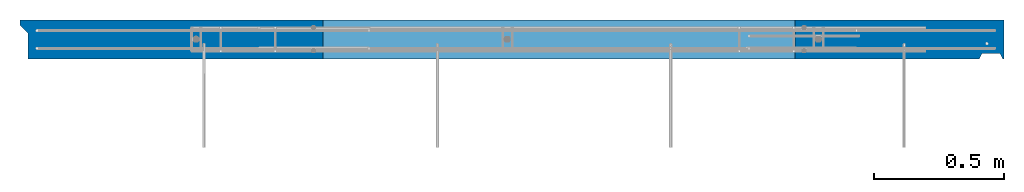
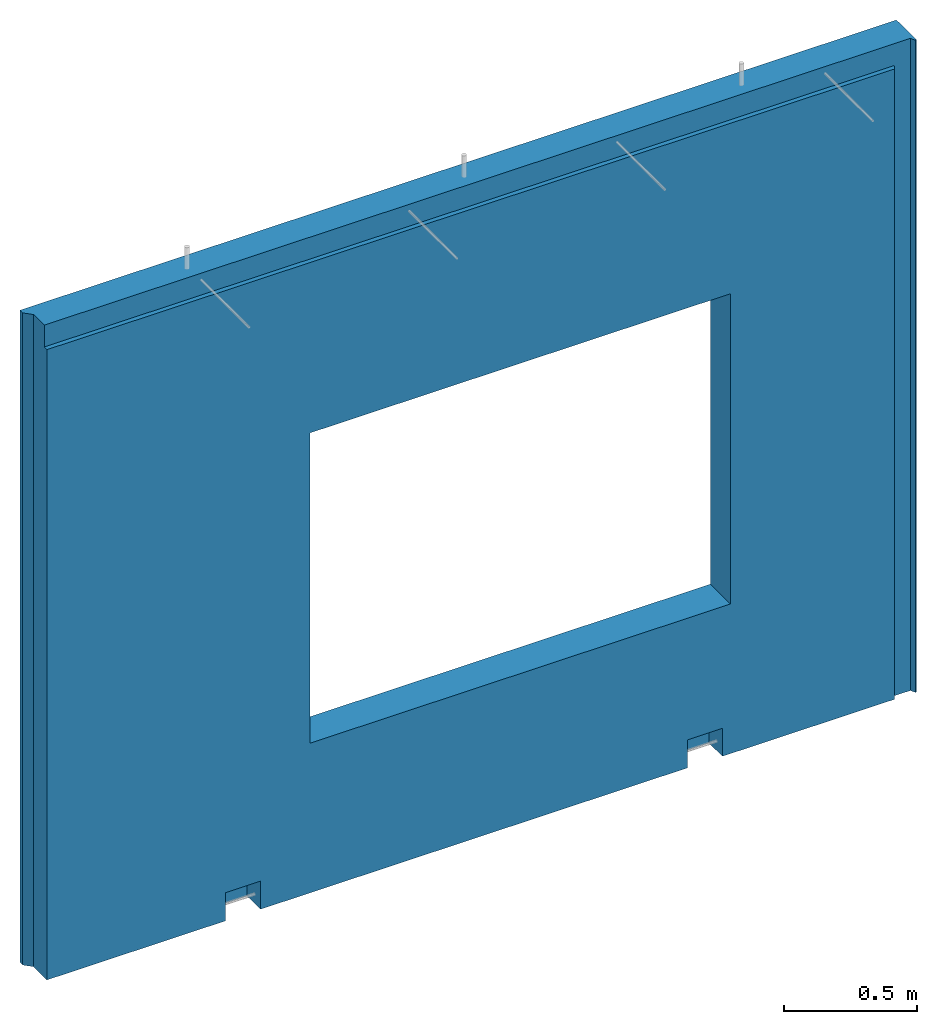
# One storey, part 3 of 3: 1 wall, 1 element without a shape of its own.
"""IFC2X3 building model written with IfcOpenShell, lengths in millimetres."""

import ifcopenshell
import ifcopenshell.guid

model = None  # the IFC model being written
_history = None  # IfcOwnerHistory: only IFC2X3 demands one
_inside = {}  # id of a spatial element -> (the spatial element, [elements in it])
_under = {}  # id of a project, library or spatial element -> (it, [spatial elements below it])
_declared = {}  # id of a project -> (the project, [libraries it declares])
_typed = {}  # id of a type object -> (the type object, [elements of that type])
_made_of = {}  # id of a material, layer set ... -> (it, [elements and type objects made of it])


def new_model(schema):
    """Start an empty IFC model of exactly this schema.

    Asked for "IFC4X3", IfcOpenShell would pick the latest addendum, in which some entities
    have other attributes; the version numbers below select the first issue.
    IFC2X3 requires an IfcOwnerHistory on every rooted entity: one is made here for all.
    """
    global model, _history
    if schema == "IFC4X3":
        model = ifcopenshell.file(schema_version=(4, 3, 0, 0))
    else:
        model = ifcopenshell.file(schema=schema)
    _inside.clear()
    _under.clear()
    _declared.clear()
    _typed.clear()
    _made_of.clear()
    _history = None
    if model.schema == "IFC2X3":
        org = make("IfcOrganization", Name="unknown")
        user = make(
            "IfcPersonAndOrganization",
            ThePerson=make("IfcPerson", FamilyName="unknown"),
            TheOrganization=org,
        )
        app = make(
            "IfcApplication",
            ApplicationDeveloper=org,
            Version="unknown",
            ApplicationFullName="unknown",
            ApplicationIdentifier="unknown",
        )
        _history = make(
            "IfcOwnerHistory",
            OwningUser=user,
            OwningApplication=app,
            ChangeAction="ADDED",
            CreationDate=0,
        )
    return model


def make(cls, **values):
    """One entity of the class cls with the attributes given. An attribute that is None is left unset."""
    return model.create_entity(
        cls, **{name: value for name, value in values.items() if value is not None}
    )


def rooted(cls, **values):
    """An entity with a GlobalId (a new one), such as an element, a storey or a relation."""
    return make(cls, GlobalId=ifcopenshell.guid.new(), OwnerHistory=_history, **values)


def si_unit(unit_type, name, prefix=None):
    """IfcSIUnit, for example si_unit("LENGTHUNIT", "METRE", prefix="MILLI")."""
    return make("IfcSIUnit", UnitType=unit_type, Prefix=prefix, Name=name)


def assignment(units):
    """IfcUnitAssignment: the units of a project."""
    return None if units is None else make("IfcUnitAssignment", Units=units)


def point(xyz):
    """IfcCartesianPoint."""
    return None if xyz is None else make("IfcCartesianPoint", Coordinates=xyz)


def direction(xyz):
    """IfcDirection."""
    return None if xyz is None else make("IfcDirection", DirectionRatios=xyz)


def frame(location, z_axis=None, x_axis=None):
    """IfcAxis2Placement3D, a coordinate frame: its origin and axes. An axis left out is left unset."""
    return make(
        "IfcAxis2Placement3D",
        Location=point(location),
        Axis=direction(z_axis),
        RefDirection=direction(x_axis),
    )


def origin_with_axes():
    """The frame at (0, 0, 0) with the z axis (0, 0, 1) and the x axis (1, 0, 0) written out."""
    return frame((0.0, 0.0, 0.0), z_axis=(0.0, 0.0, 1.0), x_axis=(1.0, 0.0, 0.0))


def place(relative_to, where):
    """IfcLocalPlacement: puts the frame where relative to a parent placement (None: the world)."""
    return make(
        "IfcLocalPlacement", PlacementRelTo=relative_to, RelativePlacement=where
    )


def context(
    kind, dimensions, precision=None, world=None, true_north=None, identifier=None
):
    """IfcGeometricRepresentationContext, for example the 3D "Model" context."""
    return make(
        "IfcGeometricRepresentationContext",
        ContextIdentifier=identifier,
        ContextType=kind,
        CoordinateSpaceDimension=dimensions,
        Precision=precision,
        WorldCoordinateSystem=world,
        TrueNorth=true_north,
    )


def subcontext(parent, identifier, kind, view, scale=None):
    """IfcGeometricRepresentationSubContext, for example "Body" below "Model"."""
    return make(
        "IfcGeometricRepresentationSubContext",
        ContextIdentifier=identifier,
        ContextType=kind,
        ParentContext=parent,
        TargetScale=scale,
        TargetView=view,
    )


def project(units=None, contexts=None):
    """IfcProject with its units and contexts."""
    return rooted(
        "IfcProject",
        Name="project",
        RepresentationContexts=contexts,
        UnitsInContext=assignment(units),
    )


def spatial(cls, under=None, at=None, **own):
    """A site, building, storey or space (cls), placed at a placement, below another one or the project."""
    s = rooted(cls, ObjectPlacement=at, **own)
    if under is not None:
        _under.setdefault(under.id(), (under, []))[1].append(s)
    return s


def faces_of(points, faces, orient=None, outer=None):
    """IfcFace entities. A face is a list of loops; a loop is a list of indices into points, from 0.

    orient and outer hold one flag for each loop. By default every Orientation is true, the
    first loop of a face is its IfcFaceOuterBound and the others are IfcFaceBound.
    """
    made = []
    for i, loops in enumerate(faces):
        bounds = []
        for j, loop in enumerate(loops):
            is_outer = j == 0 if outer is None else outer[i][j]
            bounds.append(
                make(
                    "IfcFaceOuterBound" if is_outer else "IfcFaceBound",
                    Bound=make("IfcPolyLoop", Polygon=[points[k] for k in loop]),
                    Orientation=True if orient is None else orient[i][j],
                )
            )
        made.append(make("IfcFace", Bounds=bounds))
    return made


def faceted_brep(points, faces, orient=None, outer=None, voids=None):
    """IfcFacetedBrep: a solid bounded by flat faces; with voids (closed shells), ...WithVoids."""
    shared = [point(p) for p in points]
    hull = make("IfcClosedShell", CfsFaces=faces_of(shared, faces, orient, outer))
    if voids is None:
        return make("IfcFacetedBrep", Outer=hull)
    return make(
        "IfcFacetedBrepWithVoids",
        Outer=hull,
        Voids=[
            make(cls, CfsFaces=faces_of(shared, fs, o, b)) for cls, fs, o, b in voids
        ],
    )


def shape(context_of_items, identifier, shape_type, items):
    """IfcShapeRepresentation: the items that make up one representation, for example the "Body"."""
    return make(
        "IfcShapeRepresentation",
        ContextOfItems=context_of_items,
        RepresentationIdentifier=identifier,
        RepresentationType=shape_type,
        Items=items,
    )


def material(Name=None, Category=None):
    """IfcMaterial."""
    return make("IfcMaterial", Name=Name, Category=Category)


def made_of(thing, what):
    """Note that an element or type object is made of a material, layer set ...; save() writes the relation."""
    if what is not None:
        _made_of.setdefault(what.id(), (what, []))[1].append(thing)
    return thing


def type_object(cls, material=None, **own):
    """A type object (cls), such as IfcWallType, which elements share."""
    return made_of(rooted(cls, **own), material)


def element(
    cls,
    number,
    at=None,
    inside=None,
    cuts=None,
    type_object=None,
    material=None,
    context=None,
    identifier="Body",
    shape_type=None,
    held_by="IfcProductDefinitionShape",
    body=None,
    shapes=None,
    **own,
):
    """One element of the class cls, such as IfcWall. Its Tag is "e" and its number.

    at: its placement. inside: the storey or other place that contains it. cuts: it is an
    opening in that element (IfcRelVoidsElement). A single representation is given by context,
    identifier, shape_type and body (its items); several are given by shapes. held_by: the class
    of the entity that holds the representations. save() writes the other relations.
    """
    e = rooted(cls, Tag="e%d" % number, ObjectPlacement=at, **own)
    if body is not None:
        shapes = [shape(context, identifier, shape_type, body)]
    if shapes is not None:
        e.Representation = make(held_by, Representations=shapes)
    if inside is not None:
        _inside.setdefault(inside.id(), (inside, []))[1].append(e)
    if cuts is not None:
        rooted(
            "IfcRelVoidsElement", RelatingBuildingElement=cuts, RelatedOpeningElement=e
        )
    if type_object is not None:
        _typed.setdefault(type_object.id(), (type_object, []))[1].append(e)
    return made_of(e, material)


def aggregate(whole, parts):
    """IfcRelAggregates: a whole, such as a stair, and the parts it consists of."""
    return rooted("IfcRelAggregates", RelatingObject=whole, RelatedObjects=parts)


def save(model, path):
    """Write the relations noted so far, then the file.

    IfcRelAggregates (storeys below a building ...), IfcRelContainedInSpatialStructure (elements
    in a storey), IfcRelDefinesByType, IfcRelAssociatesMaterial and IfcRelDeclares: one each for
    every whole, place, type object, material and project.
    """
    for whole, parts in _under.values():
        aggregate(whole, parts)
    for where, things in _inside.values():
        rooted(
            "IfcRelContainedInSpatialStructure",
            RelatedElements=things,
            RelatingStructure=where,
        )
    for kind, things in _typed.values():
        rooted("IfcRelDefinesByType", RelatedObjects=things, RelatingType=kind)
    for what, things in _made_of.values():
        rooted("IfcRelAssociatesMaterial", RelatedObjects=things, RelatingMaterial=what)
    for by, libraries in _declared.values():
        rooted("IfcRelDeclares", RelatingContext=by, RelatedDefinitions=libraries)
    model.write(path)


model = new_model("IFC2X3")

# Units and contexts
model_context = context("Model", 3, precision=1e-05, world=origin_with_axes())
body_context = subcontext(model_context, "Body", "Model", "MODEL_VIEW")
ifc_project = project(units=[si_unit("LENGTHUNIT", "METRE", prefix="MILLI"), si_unit("AREAUNIT", "SQUARE_METRE"), si_unit("VOLUMEUNIT", "CUBIC_METRE"), si_unit("MASSUNIT", "GRAM", prefix="KILO"), si_unit("TIMEUNIT", "SECOND"), si_unit("PLANEANGLEUNIT", "RADIAN"), si_unit("SOLIDANGLEUNIT", "STERADIAN"), si_unit("THERMODYNAMICTEMPERATUREUNIT", "DEGREE_CELSIUS"), si_unit("LUMINOUSINTENSITYUNIT", "LUMEN")], contexts=[model_context])

# Site, building, storey
site_placement = place(None, origin_with_axes())
site = spatial("IfcSite", under=ifc_project, at=site_placement, CompositionType="ELEMENT")
building_placement = place(site_placement, origin_with_axes())
building = spatial("IfcBuilding", under=site, at=building_placement, Name="1", CompositionType="ELEMENT")
storey_placement = place(building_placement, origin_with_axes())
storey = spatial("IfcBuildingStorey", under=building, at=storey_placement, Name="1. kerros", CompositionType="ELEMENT", Elevation=0.0)

# Assembly, wall
assembly_placement = place(storey_placement, origin_with_axes())
assembly = element("IfcElementAssembly", 1, at=assembly_placement, inside=storey, AssemblyPlace="NOTDEFINED", PredefinedType="REINFORCEMENT_UNIT")
ifc_material = material(Name="CONCRETE/C30/37")
wall_type = type_object("IfcWallType", Name="2985X150", PredefinedType="NOTDEFINED")
wall_placement = place(assembly_placement, frame((35970.0022627602, 6575.00033187657, 1492.49992151562), z_axis=(0.0, 0.0, 1.0), x_axis=(0.999999999544916, -3.0168999986316e-05, 0.0)))
wall = element("IfcWall", 2, at=wall_placement, type_object=wall_type, material=ifc_material, ObjectType="2985X150", context=body_context, shape_type="Brep", body=[
    faceted_brep([(1168.51782573503, 75.0, 612.500000000013), (1168.51782573502, -74.9999999549527, 612.500000000013), (1168.51782573502, -74.9999999549527, -807.499999999989), (1168.51782573503, 75.0, -807.499999999989), (2988.51782573503, -74.9999999549527, -807.499999999989), (2988.51782573503, 74.9999999999991, -807.499999999989), (2988.51782573503, -74.9999999549527, 612.500000000011), (2988.51782573503, 74.9999999999991, 612.500000000011), (2954.07959462526, 25.0190447048253, -1492.49910688857), (2954.07959462526, 25.0190447048253, -1396.08409179239), (2804.07959460707, 25.0191732548255, -1396.08409179239), (2804.07959460707, 25.0191732548255, -1492.49910688863), (2954.07950892526, -75.0000000000009, -1492.5), (2954.07950892526, -74.9809552951383, -1364.1894376532), (2804.07950890707, -74.9808267451381, -1364.1894376532), (2804.07950890707, -75.0000000000009, -1492.5), (954.079720502159, 25.0032248074531, -1492.49627628797), (954.079720502159, 25.0032248074531, -1395.30681099557), (804.079720483431, 25.0033533574533, -1395.30681099557), (804.079720483431, 25.0033533574533, -1492.49627628797), (954.079634802169, -75.0000000000009, -1492.5), (954.079634802169, -74.9967751925105, -1363.41215685638), (804.07963478344, -74.9966466425103, -1363.41215685638), (804.07963478344, -75.0000000000009, -1492.5), (-7.27595761418343e-12, 74.9999999999991, 1492.5), (-7.27595761418343e-12, 74.9999999999991, -1492.5), (-7.27595761418343e-12, 54.9999999999054, -1492.5), (-7.27595761418343e-12, 54.9999999999054, 1492.5), (3794.40330907149, 75.0, 1492.5), (3794.40330907149, 75.0, -1492.5), (3794.40330907149, -75.0, 1492.5), (3794.40330907149, -75.0, -1492.5), (3789.40125340598, -74.9918495408328, 1492.49999999992), (3789.40125340598, -75.0, -1492.5), (3699.40125340597, -75.0, -1492.5), (3709.40125340597, -54.9918495411603, -1492.50000000008), (3709.40125340597, -54.9918495411603, 1392.49999996542), (3699.40125340597, -75.0, 1392.49999996542), (3774.99999812031, -54.9918495411603, 1492.49999999992), (3709.40125340597, -55.0000000734208, 1492.49999996542), (3779.40125340597, -54.9918495411603, -1492.50000000008), (3779.40125340597, -54.9918495411603, 1492.49999999992), (29.9999999793945, -75.0000000000009, -1492.5), (29.9999999793945, 24.9999999999054, -1492.5), (29.9999999793945, 24.9999999999054, 1492.5), (29.9999999793945, -55.0000000734208, 1492.5), (29.999999953885, -55.0000000734208, 1392.49999996542), (29.9999999793945, -75.0000000000009, 1392.49999996542)], [[[0, 1, 2, 3]], [[3, 2, 4, 5]], [[5, 4, 6, 7]], [[7, 6, 1, 0]], [[8, 9, 10, 11]], [[12, 13, 9, 8]], [[14, 10, 9, 13]], [[11, 10, 14, 15]], [[16, 17, 18, 19]], [[20, 21, 17, 16]], [[22, 18, 17, 21]], [[19, 18, 22, 23]], [[24, 25, 26, 27]], [[25, 24, 28, 29], [3, 5, 7, 0]], [[30, 31, 29, 28]], [[31, 30, 32, 33]], [[34, 35, 36, 37]], [[38, 39, 36, 35, 40, 41]], [[32, 41, 40, 33]], [[35, 34, 12, 8, 11, 15, 20, 16, 19, 23, 42, 43, 26, 25, 29, 31, 33, 40]], [[27, 26, 43, 44]], [[38, 41, 32, 30, 28, 24, 27, 44, 45, 39]], [[39, 45, 46, 36]], [[44, 43, 42, 47, 46, 45]], [[36, 46, 47, 37]], [[42, 23, 22, 21, 20, 15, 14, 13, 12, 34, 37, 47], [2, 1, 6, 4]]]),
])
aggregate(assembly, [wall])

save(model, "model.ifc")
